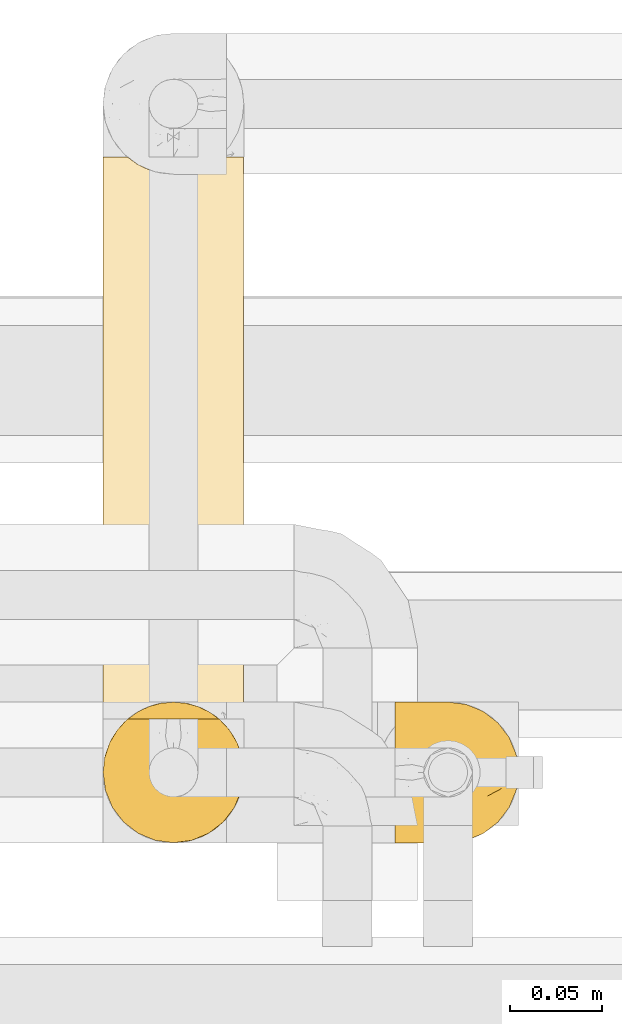
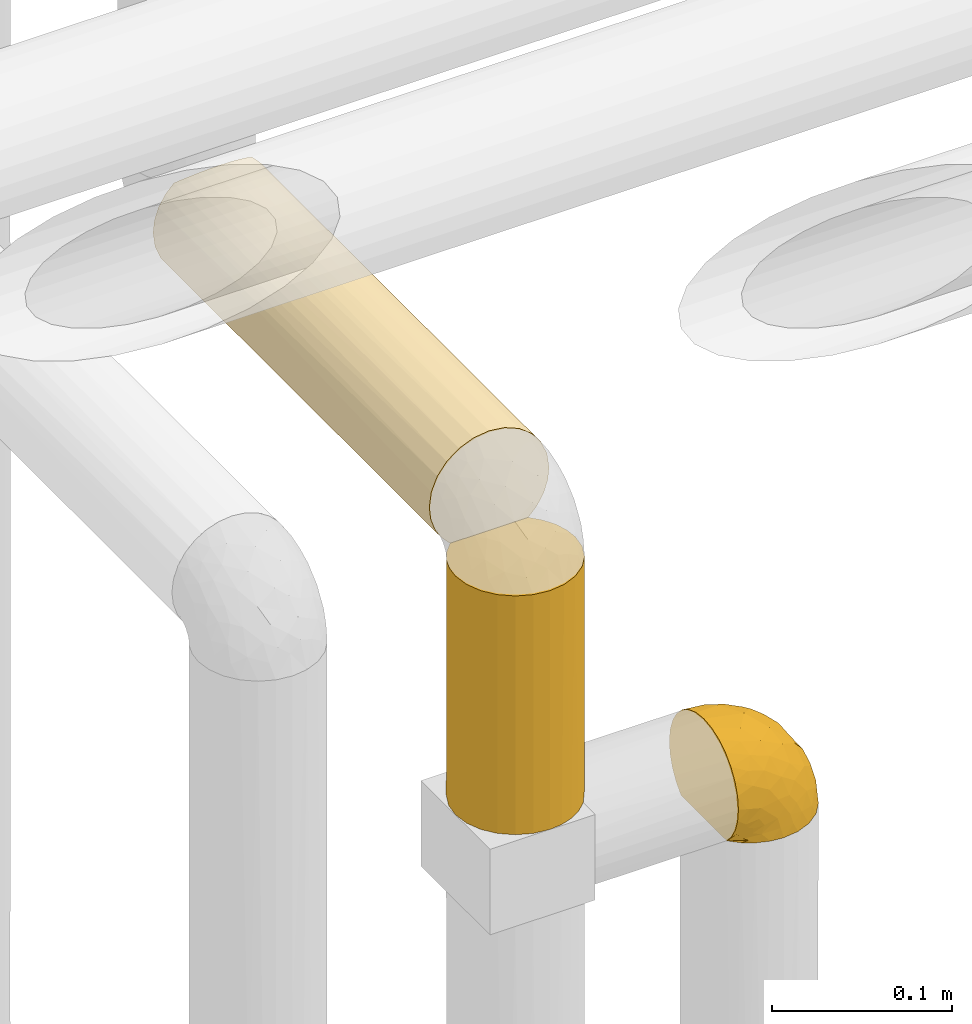
# One storey, part 280 of 827: 3 coverings.
"""IFC2X3 building model written with IfcOpenShell, lengths in millimetres."""

from ifc_helpers import new_model, entity, si_unit, converted_unit, derived_unit, direction, frame, origin, place, context, subcontext, project, spatial, faceted_brep, element, save


model = new_model("IFC2X3")

# Units and contexts
model_context = context("Model", 3, precision=0.01, world=origin(), true_north=direction((6.12303176911189e-17, 1.0)))
body_context = subcontext(model_context, "Body", "Model", "MODEL_VIEW")
ifc_project = project(units=[si_unit("LENGTHUNIT", "METRE", prefix="MILLI"), si_unit("AREAUNIT", "SQUARE_METRE"), si_unit("VOLUMEUNIT", "CUBIC_METRE"), converted_unit("PLANEANGLEUNIT", "DEGREE", entity("IfcRatioMeasure", 0.0174532925199433), si_unit("PLANEANGLEUNIT", "RADIAN"), dimensions=[0, 0, 0, 0, 0, 0, 0]), si_unit("MASSUNIT", "GRAM", prefix="KILO"), derived_unit("MASSDENSITYUNIT", [(si_unit("MASSUNIT", "GRAM", prefix="KILO"), 1), (si_unit("LENGTHUNIT", "METRE"), -3)]), derived_unit("MOMENTOFINERTIAUNIT", [(si_unit("LENGTHUNIT", "METRE"), 4)]), si_unit("TIMEUNIT", "SECOND"), si_unit("FREQUENCYUNIT", "HERTZ"), si_unit("THERMODYNAMICTEMPERATUREUNIT", "DEGREE_CELSIUS"), derived_unit("THERMALTRANSMITTANCEUNIT", [(si_unit("MASSUNIT", "GRAM", prefix="KILO"), 1), (si_unit("THERMODYNAMICTEMPERATUREUNIT", "KELVIN"), -1), (si_unit("TIMEUNIT", "SECOND"), -3)]), derived_unit("VOLUMETRICFLOWRATEUNIT", [(si_unit("LENGTHUNIT", "METRE"), 3), (si_unit("TIMEUNIT", "SECOND"), -1)]), derived_unit("MASSFLOWRATEUNIT", [(si_unit("MASSUNIT", "GRAM", prefix="KILO"), 1), (si_unit("TIMEUNIT", "SECOND"), -1)]), derived_unit("ROTATIONALFREQUENCYUNIT", [(si_unit("TIMEUNIT", "SECOND"), -1)]), si_unit("ELECTRICCURRENTUNIT", "AMPERE"), si_unit("ELECTRICVOLTAGEUNIT", "VOLT"), si_unit("POWERUNIT", "WATT"), si_unit("FORCEUNIT", "NEWTON", prefix="KILO"), si_unit("ILLUMINANCEUNIT", "LUX"), si_unit("LUMINOUSFLUXUNIT", "LUMEN"), si_unit("LUMINOUSINTENSITYUNIT", "CANDELA"), derived_unit("USERDEFINED", [(si_unit("MASSUNIT", "GRAM", prefix="KILO"), -1), (si_unit("LENGTHUNIT", "METRE"), -2), (si_unit("TIMEUNIT", "SECOND"), 3), (si_unit("LUMINOUSFLUXUNIT", "LUMEN"), 1)]), derived_unit("LINEARVELOCITYUNIT", [(si_unit("LENGTHUNIT", "METRE"), 1), (si_unit("TIMEUNIT", "SECOND"), -1)]), si_unit("PRESSUREUNIT", "PASCAL"), derived_unit("USERDEFINED", [(si_unit("LENGTHUNIT", "METRE"), -2), (si_unit("MASSUNIT", "GRAM", prefix="KILO"), 1), (si_unit("TIMEUNIT", "SECOND"), -2)]), derived_unit("LINEARFORCEUNIT", [(si_unit("MASSUNIT", "GRAM", prefix="KILO"), 1), (si_unit("LENGTHUNIT", "METRE"), 1), (si_unit("TIMEUNIT", "SECOND"), -2), (si_unit("LENGTHUNIT", "METRE"), -1)]), derived_unit("PLANARFORCEUNIT", [(si_unit("MASSUNIT", "GRAM", prefix="KILO"), 1), (si_unit("LENGTHUNIT", "METRE"), 1), (si_unit("TIMEUNIT", "SECOND"), -2), (si_unit("LENGTHUNIT", "METRE"), -2)])], contexts=[model_context])

# Site, building, storey
site_placement = place(None, origin())
site = spatial("IfcSite", under=ifc_project, at=site_placement, CompositionType="ELEMENT")
building_placement = place(site_placement, origin())
building = spatial("IfcBuilding", under=site, at=building_placement, CompositionType="ELEMENT")
storey_placement = place(building_placement, frame((0.0, 0.0, 28200.0)))
storey = spatial("IfcBuildingStorey", under=building, at=storey_placement, Name="08", CompositionType="ELEMENT", Elevation=28200.0)

# Coverings
covering_1_placement = place(storey_placement, frame((35112.19, 14884.87, 2549.3)))
element("IfcCovering", 1, at=covering_1_placement, inside=storey, Name=":ADSK_", ObjectType=":ADSK_", PredefinedType="INSULATION", context=body_context, shape_type="Brep", body=[
    faceted_brep([(1.6, 5.41, 47.38), (1.6, 9.99, 54.67), (1.6, 16.08, 60.76), (1.6, 23.37, 65.34), (1.6, 31.49, 68.18), (1.6, 40.05, 69.15), (1.6, 48.61, 68.18), (1.6, 56.73, 65.33), (1.6, 64.02, 60.75), (1.6, 70.11, 54.66), (1.6, 74.69, 47.37), (1.6, 77.53, 39.25), (1.6, 78.5, 30.7), (1.6, 77.63, 22.59), (1.6, 75.08, 14.86), (1.6, 70.97, 7.84), (1.6, 65.47, 1.85), (1.6, 63.27, 1.85), (1.6, 61.53, 1.85), (1.6, 59.57, 1.85), (1.6, 57.6, 1.85), (1.6, 55.63, 1.85), (1.6, 53.67, 1.85), (1.6, 51.7, 1.85), (1.6, 49.73, 1.85), (1.6, 47.54, 1.85), (1.6, 45.34, 1.85), (1.6, 43.15, 1.85), (1.6, 40.96, 1.85), (1.6, 38.76, 1.85), (1.6, 36.57, 1.85), (1.6, 34.37, 1.85), (1.6, 32.18, 1.85), (1.6, 29.98, 1.85), (1.6, 27.79, 1.85), (1.6, 25.6, 1.85), (1.6, 23.4, 1.85), (1.6, 21.21, 1.85), (1.6, 19.01, 1.85), (1.6, 16.82, 1.85), (1.6, 14.62, 1.85), (1.6, 9.12, 7.85), (1.6, 5.0, 14.88), (1.6, 2.46, 22.61), (1.6, 1.6, 30.7), (1.6, 2.56, 39.26), (1.85, 65.47, 1.6), (7.85, 70.97, 1.6), (14.87, 75.09, 1.6), (22.6, 77.63, 1.6), (30.7, 78.5, 1.6), (40.65, 77.19, 1.6), (49.92, 73.34, 1.6), (57.88, 67.23, 1.6), (63.99, 59.27, 1.6), (67.84, 50.0, 1.6), (69.15, 40.05, 1.6), (67.84, 30.09, 1.6), (63.99, 20.82, 1.6), (57.88, 12.86, 1.6), (49.92, 6.75, 1.6), (40.65, 2.91, 1.6), (30.7, 1.6, 1.6), (22.6, 2.46, 1.6), (14.87, 5.0, 1.6), (7.85, 9.12, 1.6), (1.85, 14.62, 1.6), (1.85, 16.82, 1.6), (1.85, 17.8, 1.6), (1.85, 19.39, 1.6), (1.85, 20.98, 1.6), (1.85, 22.57, 1.6), (1.85, 24.16, 1.6), (1.85, 25.75, 1.6), (1.85, 27.33, 1.6), (1.85, 28.92, 1.6), (1.85, 30.51, 1.6), (1.85, 32.1, 1.6), (1.85, 33.69, 1.6), (1.85, 35.28, 1.6), (1.85, 36.87, 1.6), (1.85, 38.46, 1.6), (1.85, 40.05, 1.6), (1.85, 41.63, 1.6), (1.85, 43.22, 1.6), (1.85, 44.81, 1.6), (1.85, 46.4, 1.6), (1.85, 47.99, 1.6), (1.85, 49.58, 1.6), (1.85, 51.17, 1.6), (1.85, 52.76, 1.6), (1.85, 54.72, 1.6), (1.85, 56.69, 1.6), (1.85, 58.88, 1.6), (1.85, 61.08, 1.6), (1.85, 63.27, 1.6), (1.77, 37.77, 1.78), (1.78, 36.07, 1.77), (1.77, 32.96, 1.78), (1.77, 31.36, 1.77), (1.76, 56.52, 1.79), (1.77, 54.96, 1.78), (1.79, 18.75, 1.76), (1.78, 58.07, 1.77), (1.78, 50.37, 1.77), (1.78, 23.36, 1.76), (1.78, 24.95, 1.77), (1.78, 42.43, 1.77), (1.74, 15.97, 1.8), (1.78, 51.96, 1.76), (1.78, 53.47, 1.77), (1.77, 48.63, 1.78), (1.78, 63.93, 1.77), (1.78, 40.93, 1.77), (1.78, 29.72, 1.76), (1.77, 62.4, 1.77), (1.77, 60.92, 1.78), (1.77, 17.31, 1.77), (1.78, 21.74, 1.77), (1.78, 34.56, 1.77), (1.77, 20.18, 1.78), (1.77, 14.62, 1.77), (1.72, 14.62, 1.8), (1.66, 14.62, 1.82), (1.77, 65.47, 1.77), (1.8, 65.47, 1.72), (1.82, 65.47, 1.66), (1.79, 59.5, 1.76), (1.78, 47.1, 1.77), (1.79, 45.61, 1.76), (1.78, 28.18, 1.77), (1.82, 14.62, 1.66), (1.8, 14.62, 1.72), (1.76, 26.61, 1.78), (1.66, 65.47, 1.82), (1.72, 65.47, 1.8), (1.78, 39.32, 1.77), (1.77, 44.12, 1.78), (9.41, 72.26, 3.72), (17.65, 76.57, 7.41), (7.41, 71.77, 6.13), (21.47, 78.5, 21.47), (15.21, 77.9, 19.34), (16.15, 78.5, 26.8), (28.75, 78.5, 8.87), (13.67, 75.52, 9.2), (12.79, 76.13, 12.79), (19.18, 77.81, 14.62), (29.16, 78.5, 7.34), (9.04, 72.4, 5.33), (7.41, 76.56, 17.64), (5.74, 71.77, 7.7), (3.72, 72.25, 9.41), (8.87, 78.5, 28.75), (26.8, 78.5, 16.15), (9.53, 75.75, 14.14), (7.34, 78.5, 29.16), (37.63, 50.46, 57.02), (17.92, 52.75, 64.92), (27.45, 40.05, 64.0), (37.01, 77.7, 11.92), (34.22, 77.66, 19.16), (45.87, 71.02, 28.65), (56.57, 63.45, 24.62), (52.31, 70.55, 15.19), (42.07, 75.57, 18.36), (44.74, 75.57, 9.2), (21.49, 72.61, 46.98), (11.02, 72.61, 50.24), (15.64, 67.24, 56.1), (26.02, 77.74, 28.97), (36.59, 57.43, 54.46), (65.49, 47.19, 21.34), (63.99, 54.76, 18.4), (15.2, 40.05, 66.44), (60.27, 63.45, 12.07), (45.25, 60.1, 45.49), (35.21, 63.72, 50.57), (22.52, 76.83, 36.04), (12.03, 76.34, 42.07), (13.32, 60.51, 62.12), (35.9, 72.59, 37.37), (33.87, 76.05, 29.39), (25.73, 66.15, 53.59), (26.34, 60.51, 58.06), (46.78, 51.88, 49.27), (59.54, 55.34, 29.63), (60.18, 48.67, 33.21), (53.93, 53.89, 40.1), (53.36, 46.73, 44.08), (49.36, 40.05, 49.36), (38.4, 40.05, 56.68), (66.44, 40.05, 15.2), (50.09, 63.95, 35.57), (41.08, 67.24, 41.7), (31.14, 69.62, 46.4), (28.19, 73.6, 41.41), (64.0, 40.05, 27.45), (56.68, 40.05, 38.4), (43.9, 4.52, 12.99), (65.46, 32.72, 21.33), (52.22, 27.18, 42.89), (37.61, 29.63, 57.04), (15.64, 12.86, 56.11), (13.31, 19.59, 62.13), (50.02, 9.54, 21.89), (59.28, 16.64, 16.62), (53.05, 17.48, 32.9), (21.48, 7.49, 46.99), (11.01, 7.49, 50.25), (12.03, 3.75, 42.08), (41.02, 20.75, 49.91), (35.39, 2.33, 15.6), (26.8, 1.6, 16.15), (28.75, 1.6, 8.87), (7.34, 1.6, 29.16), (65.81, 26.94, 13.16), (53.28, 9.54, 10.83), (59.8, 31.21, 33.8), (61.82, 25.33, 25.02), (17.91, 27.35, 64.92), (41.4, 8.17, 32.83), (40.48, 4.3, 20.56), (26.34, 19.59, 58.07), (31.68, 2.23, 21.46), (27.68, 2.45, 28.1), (16.15, 1.6, 26.8), (21.47, 1.6, 21.47), (28.05, 12.86, 51.29), (22.54, 3.27, 36.04), (8.87, 1.6, 28.75), (37.3, 2.29, 8.45), (41.07, 12.86, 41.73), (32.24, 6.89, 39.27), (47.4, 12.43, 33.56), (35.77, 4.1, 27.29), (17.65, 3.53, 7.41), (11.06, 6.88, 3.51), (8.55, 8.16, 4.68), (6.63, 9.02, 5.52), (12.77, 5.0, 8.75), (12.79, 3.96, 12.79), (7.41, 3.52, 17.65), (18.97, 2.4, 13.9), (3.72, 7.83, 9.42), (5.76, 8.32, 7.68), (15.21, 2.19, 19.33), (9.52, 4.34, 14.13)], [[[0, 1, 2, 3, 4, 5, 6, 7, 8, 9, 10, 11, 12, 13, 14, 15, 16, 17, 18, 19, 20, 21, 22, 23, 24, 25, 26, 27, 28, 29, 30, 31, 32, 33, 34, 35, 36, 37, 38, 39, 40, 41, 42, 43, 44, 45]], [[46, 47, 48, 49, 50, 51, 52, 53, 54, 55, 56, 57, 58, 59, 60, 61, 62, 63, 64, 65, 66, 67, 68, 69, 70, 71, 72, 73, 74, 75, 76, 77, 78, 79, 80, 81, 82, 83, 84, 85, 86, 87, 88, 89, 90, 91, 92, 93, 94, 95]], [[96, 97, 30]], [[98, 77, 99]], [[100, 101, 21]], [[69, 68, 102]], [[20, 19, 103]], [[24, 23, 104]], [[20, 103, 100]], [[72, 105, 106]], [[84, 83, 107]], [[89, 88, 104]], [[108, 67, 66]], [[109, 110, 90]], [[111, 25, 24]], [[112, 17, 16]], [[82, 113, 83]], [[109, 23, 22]], [[114, 76, 75]], [[105, 36, 106]], [[104, 111, 24]], [[18, 115, 116]], [[97, 96, 80]], [[67, 108, 117]], [[105, 71, 118]], [[31, 97, 119]], [[102, 120, 69]], [[108, 121, 122, 123, 40]], [[112, 95, 115]], [[17, 115, 18]], [[94, 116, 115]], [[117, 68, 67]], [[38, 117, 39]], [[112, 124, 125, 126, 46]], [[17, 112, 115]], [[70, 120, 118]], [[39, 117, 108]], [[120, 38, 37]], [[120, 37, 118]], [[120, 70, 69]], [[116, 94, 127]], [[128, 86, 129]], [[117, 38, 102]], [[74, 130, 75]], [[99, 33, 32]], [[115, 95, 94]], [[39, 108, 40]], [[108, 66, 131, 132, 121]], [[105, 72, 71]], [[118, 37, 36]], [[71, 70, 118]], [[35, 106, 36]], [[36, 105, 118]], [[35, 133, 106]], [[74, 73, 133]], [[106, 133, 73]], [[99, 114, 33]], [[133, 35, 34]], [[73, 72, 106]], [[95, 112, 46]], [[112, 16, 134, 135, 124]], [[130, 114, 75]], [[99, 76, 114]], [[114, 130, 33]], [[34, 33, 130]], [[78, 77, 98]], [[98, 119, 78]], [[130, 133, 34]], [[133, 130, 74]], [[79, 97, 80]], [[98, 99, 32]], [[98, 32, 31]], [[77, 76, 99]], [[97, 79, 119]], [[136, 96, 29]], [[30, 97, 31]], [[136, 29, 28]], [[81, 80, 96]], [[29, 96, 30]], [[31, 119, 98]], [[119, 79, 78]], [[96, 136, 81]], [[82, 81, 136]], [[113, 107, 83]], [[84, 107, 137]], [[107, 27, 137]], [[113, 28, 107]], [[27, 107, 28]], [[85, 84, 137]], [[137, 27, 26]], [[113, 136, 28]], [[136, 113, 82]], [[109, 89, 104]], [[86, 85, 129]], [[89, 109, 90]], [[111, 87, 128]], [[26, 129, 137]], [[88, 111, 104]], [[25, 111, 128]], [[22, 110, 109]], [[23, 109, 104]], [[110, 91, 90]], [[100, 92, 101]], [[110, 22, 101]], [[91, 110, 101]], [[116, 19, 18]], [[111, 88, 87]], [[127, 103, 19]], [[25, 128, 26]], [[86, 128, 87]], [[128, 129, 26]], [[137, 129, 85]], [[120, 102, 38]], [[117, 102, 68]], [[91, 101, 92]], [[21, 101, 22]], [[93, 92, 103]], [[100, 21, 20]], [[100, 103, 92]], [[127, 93, 103]], [[93, 127, 94]], [[116, 127, 19]], [[126, 138, 47]], [[48, 138, 139]], [[140, 125, 124]], [[141, 142, 143]], [[144, 49, 139]], [[145, 140, 146]], [[48, 139, 49]], [[139, 145, 147]], [[49, 144, 148, 50]], [[126, 125, 149]], [[14, 13, 150]], [[151, 146, 140]], [[149, 140, 145]], [[152, 151, 135]], [[152, 14, 150]], [[16, 15, 134]], [[13, 153, 150]], [[124, 151, 140]], [[141, 147, 142]], [[14, 152, 15]], [[15, 152, 134]], [[47, 46, 126]], [[139, 154, 144]], [[138, 48, 47]], [[125, 140, 149]], [[135, 134, 152]], [[146, 155, 142]], [[145, 146, 147]], [[149, 139, 138]], [[147, 141, 154]], [[147, 146, 142]], [[139, 147, 154]], [[139, 149, 145]], [[149, 138, 126]], [[155, 146, 151]], [[150, 143, 142]], [[152, 155, 151]], [[150, 142, 155]], [[13, 12, 156, 153]], [[153, 143, 150]], [[152, 150, 155]], [[151, 124, 135]], [[157, 158, 159]], [[160, 154, 161]], [[162, 163, 164]], [[165, 166, 160]], [[167, 168, 169]], [[141, 170, 161]], [[156, 12, 11]], [[158, 157, 171]], [[172, 55, 173]], [[158, 6, 174]], [[175, 54, 53]], [[52, 166, 164]], [[52, 164, 53]], [[54, 175, 173]], [[166, 52, 51]], [[176, 177, 171]], [[178, 143, 179]], [[156, 11, 179]], [[8, 7, 180]], [[169, 9, 8]], [[179, 143, 153, 156]], [[179, 11, 10]], [[168, 179, 10]], [[181, 162, 182]], [[179, 167, 178]], [[183, 184, 177]], [[183, 169, 184]], [[176, 171, 185]], [[172, 186, 187]], [[158, 7, 6]], [[159, 158, 174]], [[184, 180, 158]], [[54, 173, 55]], [[180, 169, 8]], [[188, 189, 187]], [[9, 168, 10]], [[186, 188, 187]], [[190, 157, 159, 191]], [[55, 172, 192]], [[176, 193, 194]], [[161, 170, 182]], [[162, 164, 165]], [[175, 164, 163]], [[51, 50, 148]], [[167, 195, 196]], [[178, 182, 170]], [[6, 5, 174]], [[158, 180, 7]], [[169, 180, 184]], [[169, 168, 9]], [[179, 168, 167]], [[182, 162, 165]], [[162, 194, 193]], [[161, 165, 160]], [[195, 181, 196]], [[192, 172, 197]], [[192, 56, 55]], [[189, 190, 198]], [[198, 197, 187]], [[172, 187, 197]], [[185, 189, 188]], [[198, 187, 189]], [[186, 172, 173]], [[173, 163, 186]], [[193, 186, 163]], [[176, 185, 188]], [[185, 157, 190]], [[188, 186, 193]], [[177, 176, 194]], [[188, 193, 176]], [[162, 193, 163]], [[195, 177, 194]], [[171, 177, 184]], [[181, 195, 194]], [[183, 167, 169]], [[162, 181, 194]], [[196, 182, 178]], [[158, 171, 184]], [[171, 157, 185]], [[177, 195, 183]], [[167, 183, 195]], [[182, 196, 181]], [[178, 170, 143]], [[178, 167, 196]], [[164, 175, 53]], [[173, 175, 163]], [[160, 51, 148]], [[164, 166, 165]], [[51, 160, 166]], [[160, 148, 144, 154]], [[141, 161, 154]], [[182, 165, 161]], [[190, 189, 185]], [[143, 170, 141]], [[60, 199, 61]], [[197, 200, 192]], [[201, 190, 202]], [[200, 57, 192]], [[203, 204, 2]], [[205, 206, 207]], [[208, 209, 210]], [[211, 207, 201]], [[212, 213, 214]], [[45, 215, 210]], [[216, 206, 58]], [[45, 44, 215]], [[59, 217, 60]], [[60, 217, 199]], [[0, 45, 210]], [[218, 201, 219]], [[202, 159, 220]], [[205, 221, 222]], [[223, 204, 203]], [[1, 203, 2]], [[57, 200, 216]], [[220, 3, 204]], [[220, 174, 4]], [[1, 0, 209]], [[212, 224, 213]], [[225, 226, 227]], [[228, 223, 203]], [[208, 210, 229]], [[210, 226, 229]], [[3, 220, 4]], [[58, 206, 59]], [[209, 203, 1]], [[202, 220, 223]], [[228, 203, 208]], [[202, 211, 201]], [[3, 2, 204]], [[202, 190, 191, 159]], [[210, 215, 230, 226]], [[199, 212, 231]], [[232, 233, 221]], [[233, 208, 229]], [[207, 206, 219]], [[217, 206, 205]], [[227, 224, 225]], [[233, 232, 228]], [[201, 207, 219]], [[234, 232, 221]], [[218, 219, 200]], [[202, 223, 211]], [[174, 220, 159]], [[174, 5, 4]], [[61, 231, 62]], [[220, 204, 223]], [[210, 209, 0]], [[203, 209, 208]], [[225, 233, 229]], [[224, 227, 213]], [[221, 233, 235]], [[57, 56, 192]], [[198, 218, 197]], [[200, 219, 216]], [[201, 198, 190]], [[197, 218, 200]], [[198, 201, 218]], [[206, 216, 219]], [[58, 57, 216]], [[231, 212, 214]], [[222, 212, 199]], [[228, 211, 223]], [[207, 211, 232]], [[62, 231, 214]], [[199, 231, 61]], [[233, 228, 208]], [[211, 228, 232]], [[222, 221, 235]], [[234, 205, 207]], [[206, 217, 59]], [[199, 217, 205]], [[205, 222, 199]], [[224, 222, 235]], [[222, 224, 212]], [[224, 235, 225]], [[233, 225, 235]], [[226, 225, 229]], [[205, 234, 221]], [[207, 232, 234]], [[63, 214, 236]], [[214, 213, 236]], [[214, 63, 62]], [[237, 236, 238]], [[238, 132, 131]], [[236, 237, 64]], [[239, 240, 241]], [[63, 236, 64]], [[131, 66, 65]], [[237, 131, 65]], [[242, 230, 43]], [[237, 65, 64]], [[239, 121, 132]], [[42, 242, 43]], [[241, 240, 243]], [[41, 123, 244]], [[43, 230, 215, 44]], [[244, 122, 245]], [[227, 246, 243]], [[241, 243, 246]], [[121, 239, 245]], [[41, 40, 123]], [[132, 238, 239]], [[244, 42, 41]], [[131, 237, 238]], [[240, 239, 238]], [[245, 239, 241]], [[247, 241, 246]], [[247, 244, 245]], [[238, 236, 240]], [[243, 236, 213]], [[236, 243, 240]], [[226, 246, 227]], [[243, 213, 227]], [[226, 242, 246]], [[241, 247, 245]], [[246, 242, 247]], [[244, 247, 242]], [[242, 226, 230]], [[42, 244, 242]], [[122, 244, 123]], [[122, 121, 245]]]),
])
covering_2_placement = place(storey_placement, frame((34952.89, 14884.92, 2607.4)))
element("IfcCovering", 2, at=covering_2_placement, inside=storey, Name=":ADSK_", ObjectType=":ADSK_", PredefinedType="INSULATION", context=body_context, shape_type="Brep", body=[
    faceted_brep([(6.74, 20.8, 1.6), (2.9, 30.06, 1.6), (1.6, 40.0, 1.6), (2.9, 49.93, 1.6), (6.74, 59.2, 1.6), (12.84, 67.15, 1.6), (20.8, 73.25, 1.6), (30.06, 77.09, 1.6), (40.0, 78.4, 1.6), (48.16, 77.52, 1.6), (55.94, 74.93, 1.6), (62.99, 70.75, 1.6), (69.0, 65.17, 1.6), (69.0, 14.82, 1.6), (62.99, 9.24, 1.6), (55.94, 5.06, 1.6), (48.16, 2.47, 1.6), (40.0, 1.6, 1.6), (30.06, 2.9, 1.6), (20.8, 6.74, 1.6), (12.84, 12.84, 1.6), (2.48, 48.2, 163.5), (1.6, 40.0, 163.5), (2.9, 30.06, 163.5), (6.74, 20.8, 163.5), (12.84, 12.84, 163.5), (20.8, 6.74, 163.5), (30.06, 2.9, 163.5), (40.0, 1.6, 163.5), (49.93, 2.9, 163.5), (59.2, 6.74, 163.5), (67.15, 12.84, 163.5), (73.25, 20.8, 163.5), (77.09, 30.06, 163.5), (78.4, 40.0, 163.5), (77.51, 48.2, 163.5), (74.9, 56.01, 163.5), (70.68, 63.08, 163.5), (65.05, 69.1, 163.5), (14.94, 69.1, 163.5), (9.31, 63.08, 163.5), (5.09, 56.01, 163.5), (20.48, 73.07, 159.52), (26.63, 76.0, 156.6), (33.21, 77.79, 154.8), (40.0, 78.4, 154.2), (46.78, 77.79, 154.8), (53.36, 76.0, 156.6), (59.51, 73.07, 159.52), (73.01, 59.61, 5.61), (75.97, 53.43, 8.57), (77.78, 46.82, 10.38), (78.4, 40.0, 11.0), (77.78, 33.17, 10.38), (75.97, 26.56, 8.57), (73.01, 20.38, 5.61)], [[[0, 1, 2, 3, 4, 5, 6, 7, 8, 9, 10, 11, 12, 13, 14, 15, 16, 17, 18, 19, 20]], [[21, 22, 23, 24, 25, 26, 27, 28, 29, 30, 31, 32, 33, 34, 35, 36, 37, 38, 39, 40, 41]], [[27, 26, 19, 18]], [[28, 27, 18, 17]], [[26, 25, 20, 19]], [[1, 0, 24, 23]], [[2, 1, 23, 22]], [[25, 24, 0, 20]], [[2, 22, 21]], [[3, 21, 41]], [[4, 41, 40]], [[2, 21, 3]], [[3, 41, 4]], [[40, 5, 4]], [[40, 39, 5]], [[39, 42, 6]], [[43, 44, 7]], [[42, 43, 6]], [[6, 43, 7]], [[8, 7, 44]], [[45, 8, 44]], [[39, 6, 5]], [[46, 47, 9]], [[48, 38, 11]], [[47, 48, 10]], [[45, 46, 8]], [[9, 8, 46]], [[47, 10, 9]], [[48, 11, 10]], [[38, 12, 11]], [[49, 37, 36]], [[50, 36, 35]], [[51, 35, 34]], [[49, 12, 37]], [[51, 50, 35]], [[52, 51, 34]], [[49, 36, 50]], [[37, 12, 38]], [[53, 52, 34]], [[53, 34, 33]], [[54, 33, 32]], [[54, 53, 33]], [[13, 55, 32]], [[54, 32, 55]], [[32, 31, 13]], [[14, 31, 30]], [[15, 30, 29]], [[16, 29, 28]], [[14, 30, 15]], [[15, 29, 16]], [[28, 17, 16]], [[31, 14, 13]], [[12, 49, 50, 51, 52, 53, 54, 55, 13]], [[47, 46, 45, 44, 43, 42, 39, 38, 48]]]),
])
covering_3_placement = place(storey_placement, frame((34952.89, 14952.42, 2760.0)))
element("IfcCovering", 3, at=covering_3_placement, inside=storey, Name=":ADSK_", ObjectType=":ADSK_", PredefinedType="INSULATION", context=body_context, shape_type="Brep", body=[
    faceted_brep([(5.09, 308.48, 56.01), (9.31, 308.48, 63.08), (14.94, 308.48, 69.1), (65.05, 308.48, 69.1), (70.68, 308.48, 63.08), (74.9, 308.48, 56.01), (77.51, 308.48, 48.2), (78.4, 308.48, 40.0), (77.09, 308.48, 30.06), (73.25, 308.48, 20.8), (67.15, 308.48, 12.84), (59.2, 308.48, 6.74), (49.93, 308.48, 2.9), (40.0, 308.48, 1.6), (30.06, 308.48, 2.9), (20.8, 308.48, 6.74), (12.84, 308.48, 12.84), (6.74, 308.48, 20.8), (2.9, 308.48, 30.06), (1.6, 308.48, 40.0), (2.48, 308.48, 48.2), (40.0, 1.6, 78.4), (30.06, 1.6, 77.09), (20.8, 1.6, 73.25), (12.84, 1.6, 67.15), (6.74, 1.6, 59.2), (2.9, 1.6, 49.93), (1.6, 1.6, 40.0), (2.48, 1.6, 31.79), (5.09, 1.6, 23.98), (9.31, 1.6, 16.91), (14.94, 1.6, 10.9), (65.05, 1.6, 10.9), (70.68, 1.6, 16.91), (74.9, 1.6, 23.98), (77.51, 1.6, 31.79), (78.4, 1.6, 40.0), (77.09, 1.6, 49.93), (73.25, 1.6, 59.2), (67.15, 1.6, 67.15), (59.2, 1.6, 73.25), (49.93, 1.6, 77.09), (59.51, 5.57, 6.92), (53.36, 8.5, 4.0), (46.78, 10.29, 2.2), (40.0, 10.9, 1.6), (33.21, 10.29, 2.2), (26.63, 8.5, 4.0), (20.48, 5.57, 6.92), (26.63, 301.58, 76.0), (33.21, 299.79, 77.79), (40.0, 299.18, 78.4), (20.48, 304.51, 73.07), (46.78, 299.79, 77.79), (53.36, 301.58, 76.0), (59.51, 304.51, 73.07)], [[[0, 1, 2, 3, 4, 5, 6, 7, 8, 9, 10, 11, 12, 13, 14, 15, 16, 17, 18, 19, 20]], [[21, 22, 23, 24, 25, 26, 27, 28, 29, 30, 31, 32, 33, 34, 35, 36, 37, 38, 39, 40, 41]], [[36, 35, 7]], [[35, 34, 8]], [[9, 34, 33]], [[7, 35, 8]], [[9, 8, 34]], [[10, 9, 33]], [[33, 32, 10]], [[32, 42, 11]], [[43, 44, 12]], [[42, 43, 11]], [[11, 43, 12]], [[13, 12, 44]], [[45, 13, 44]], [[32, 11, 10]], [[46, 47, 14]], [[48, 31, 15]], [[47, 48, 15]], [[45, 46, 13]], [[13, 46, 14]], [[47, 15, 14]], [[31, 16, 15]], [[17, 30, 29]], [[18, 29, 28]], [[19, 28, 27]], [[16, 30, 17]], [[17, 29, 18]], [[28, 19, 18]], [[30, 16, 31]], [[20, 27, 26]], [[0, 26, 25]], [[1, 25, 24]], [[19, 27, 20]], [[20, 26, 0]], [[25, 1, 0]], [[24, 2, 1]], [[49, 23, 22]], [[22, 21, 50]], [[51, 50, 21]], [[52, 2, 23]], [[50, 49, 22]], [[52, 23, 49]], [[23, 2, 24]], [[53, 51, 21]], [[53, 21, 41]], [[54, 41, 40]], [[54, 53, 41]], [[3, 55, 40]], [[54, 40, 55]], [[40, 39, 3]], [[4, 39, 38]], [[5, 38, 37]], [[6, 37, 36]], [[4, 38, 5]], [[5, 37, 6]], [[36, 7, 6]], [[39, 4, 3]], [[52, 49, 50, 51, 53, 54, 55, 3, 2]], [[48, 47, 46, 45, 44, 43, 42, 32, 31]]]),
])

save(model, "model.ifc")
